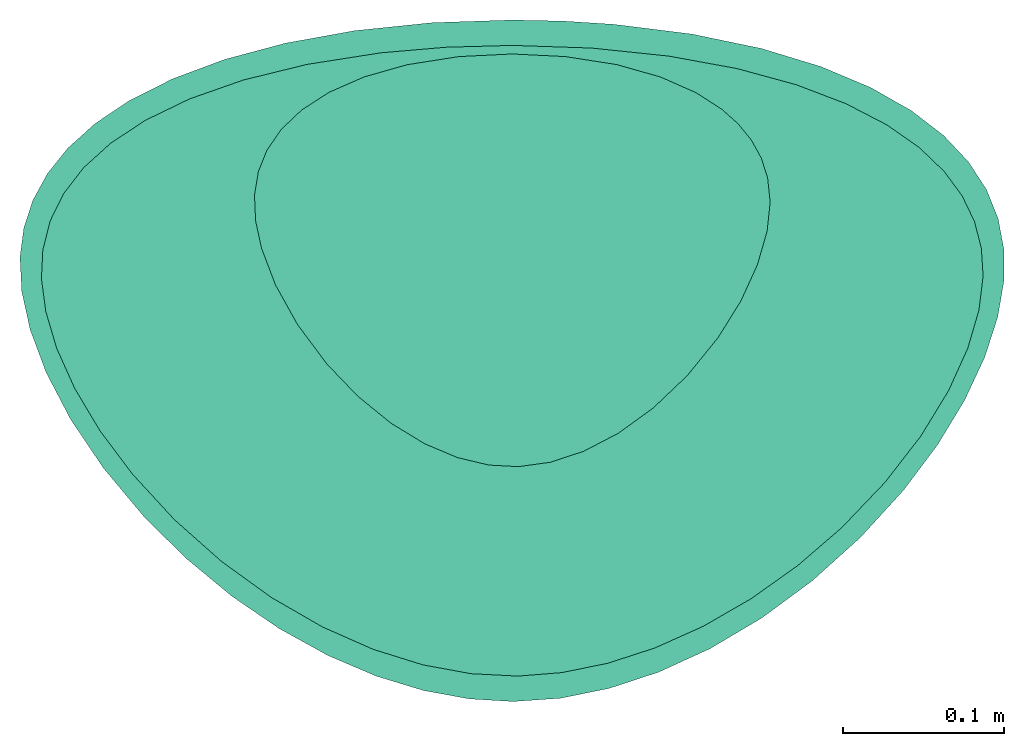
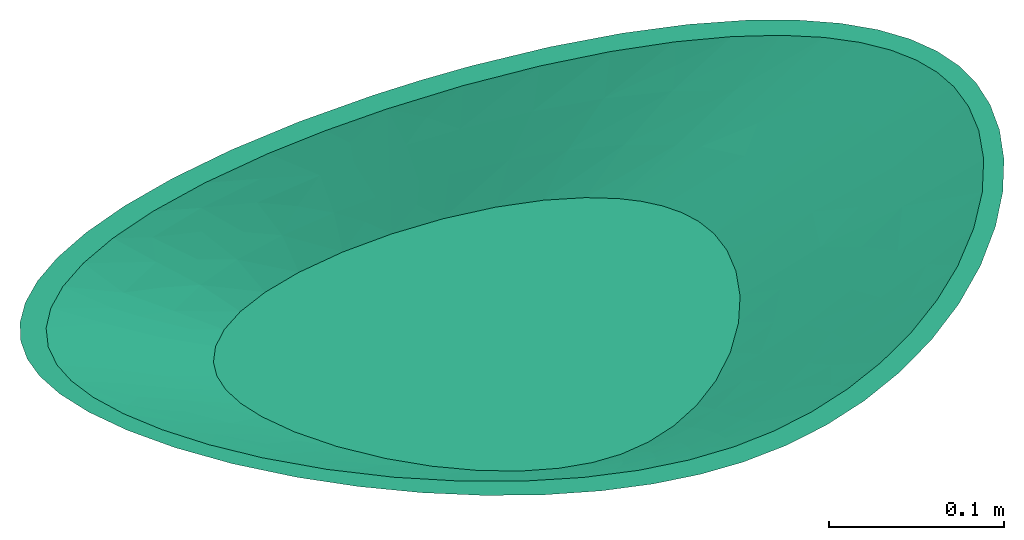
# Not in any storey: 1 sanitary terminal.
"""IFC4 building model written with IfcOpenShell, lengths in millimetres."""

from ifc_helpers import new_model, entity, si_unit, direction, origin, place, context, subcontext, project, spatial, source, transform, mapped, material, type_object, type_shapes, element, save


model = new_model("IFC4")

# Units and contexts
model_context_1 = context("Model", 3, precision=0.0001, world=origin(), true_north=direction((0.0, 1.0)))
model_context_2 = context("Model", 3, precision=0.0001, world=origin(), true_north=direction((0.0, 1.0)))
body_context = subcontext(model_context_1, "Body", "Model", "MODEL_VIEW")
ifc_project = project(units=[si_unit("LENGTHUNIT", "METRE", prefix="MILLI"), si_unit("PLANEANGLEUNIT", "RADIAN"), si_unit("TIMEUNIT", "SECOND")], contexts=[model_context_2])

# Building
building_placement = place(None, origin())
building = spatial("IfcBuilding", under=ifc_project, at=building_placement, Name="IfcBuilding", CompositionType="ELEMENT")

# Sanitary terminal
ifc_material = material(Name="Ceramic")
sanitary_terminal_type = type_object("IfcSanitaryTerminalType", PredefinedType="WASHHANDBASIN", material=ifc_material)
cartesian_point_1 = entity("IfcCartesianPoint", [0.0, 253.099263998677, 0.0])
vertex_point_1 = entity("IfcVertexPoint", cartesian_point_1)
cartesian_point_2 = entity("IfcCartesianPoint", [0.0, 247.792422124388, -83.9999999999991])
vertex_point_2 = entity("IfcVertexPoint", cartesian_point_2)
edge_curve_1 = entity("IfcEdgeCurve", vertex_point_1, vertex_point_2, entity("IfcPolyline", [cartesian_point_1, cartesian_point_2]), True)
cartesian_point_3 = entity("IfcCartesianPoint", [239.758213537139, 192.193559404919, -83.9999999999991])
cartesian_point_4 = entity("IfcCartesianPoint", [0.0, 275.591853484122, -83.9999999999991])
cartesian_point_5 = entity("IfcCartesianPoint", [-239.75821353295, 192.193559404918, -83.9999999999991])
edge_curve_2 = entity("IfcEdgeCurve", vertex_point_2, vertex_point_2, entity("IfcBSplineCurveWithKnots", 3, [cartesian_point_3, cartesian_point_4, cartesian_point_5, entity("IfcCartesianPoint", [0.0, -108.13323051355, -83.9999999999991]), cartesian_point_3, cartesian_point_4, cartesian_point_5], "UNSPECIFIED", True, True, [1, 1, 1, 1, 1, 1, 1, 1, 1, 1, 1], [-7.0, -6.0, -5.0, -4.0, -3.0, -2.0, -1.0, 0.0, 1.0, 2.0, 3.0], "UNSPECIFIED"), True)
edge_curve_3 = entity("IfcEdgeCurve", vertex_point_1, vertex_point_1, entity("IfcBSplineCurveWithKnots", 3, [entity("IfcCartesianPoint", [-437.751000004175, 168.150654933496]), entity("IfcCartesianPoint", [0.0, 295.573568531267]), entity("IfcCartesianPoint", [437.751000006541, 168.150654933498]), entity("IfcCartesianPoint", [0.0, -290.713822148428]), entity("IfcCartesianPoint", [-437.751000004175, 168.150654933496]), entity("IfcCartesianPoint", [0.0, 295.573568531267]), entity("IfcCartesianPoint", [437.751000006541, 168.150654933498])], "UNSPECIFIED", True, True, [1, 1, 1, 1, 1, 1, 1, 1, 1, 1, 1], [-7.0, -6.0, -5.0, -4.0, -3.0, -2.0, -1.0, 0.0, 1.0, 2.0, 3.0], "UNSPECIFIED"), True)
cartesian_point_6 = entity("IfcCartesianPoint", [437.751000006541, 168.150654933498, 0.0])
cartesian_point_7 = entity("IfcCartesianPoint", [0.0, 295.573568531267, 0.0])
cartesian_point_8 = entity("IfcCartesianPoint", [-437.751000004175, 168.150654933496, 0.0])
cartesian_point_9 = entity("IfcCartesianPoint", [371.75340451674, 176.164956423972, -27.9999999999997])
cartesian_point_10 = entity("IfcCartesianPoint", [0.0, 288.912996848885, -27.9999999999997])
cartesian_point_11 = entity("IfcCartesianPoint", [-371.753404513767, 176.16495642397, -27.9999999999997])
cartesian_point_12 = entity("IfcCartesianPoint", [305.75580902694, 184.179257914445, -55.9999999999994])
cartesian_point_13 = entity("IfcCartesianPoint", [0.0, 282.252425166504, -55.9999999999994])
cartesian_point_14 = entity("IfcCartesianPoint", [-305.755809023358, 184.179257914444, -55.9999999999994])
cartesian_point_15 = entity("IfcCartesianPoint", [239.758213537139, 192.193559404919, -83.9999999999991])
cartesian_point_16 = entity("IfcCartesianPoint", [0.0, 275.591853484122, -83.9999999999991])
cartesian_point_17 = entity("IfcCartesianPoint", [-239.75821353295, 192.193559404918, -83.9999999999991])
cartesian_point_18 = entity("IfcCartesianPoint", [0.0, 268.843232748677, 0.0])
vertex_point_3 = entity("IfcVertexPoint", cartesian_point_18)
cartesian_point_19 = entity("IfcCartesianPoint", [0.0, 247.792422124388, -93.9999999999991])
vertex_point_4 = entity("IfcVertexPoint", cartesian_point_19)
edge_curve_4 = entity("IfcEdgeCurve", vertex_point_3, vertex_point_4, entity("IfcPolyline", [cartesian_point_18, cartesian_point_19]), True)
cartesian_point_20 = entity("IfcCartesianPoint", [-239.758213535044, 192.193559378247, -93.9999999999991])
cartesian_point_21 = entity("IfcCartesianPoint", [0.0, 275.591853497458, -93.9999999999991])
cartesian_point_22 = entity("IfcCartesianPoint", [239.758213535045, 192.193559378248, -93.9999999999991])
edge_curve_5 = entity("IfcEdgeCurve", vertex_point_4, vertex_point_4, entity("IfcBSplineCurveWithKnots", 3, [cartesian_point_20, cartesian_point_21, cartesian_point_22, entity("IfcCartesianPoint", [0.0, -108.133230500215, -93.9999999999991]), cartesian_point_20, cartesian_point_21, cartesian_point_22], "UNSPECIFIED", True, True, [1, 1, 1, 1, 1, 1, 1, 1, 1, 1, 1], [-7.0, -6.0, -5.0, -4.0, -3.0, -2.0, -1.0, 0.0, 1.0, 2.0, 3.0], "UNSPECIFIED"), True)
edge_curve_6 = entity("IfcEdgeCurve", vertex_point_3, vertex_point_3, entity("IfcBSplineCurveWithKnots", 3, [entity("IfcCartesianPoint", [457.685108750143, 177.051077752302]), entity("IfcCartesianPoint", [0.0, 314.739310246865]), entity("IfcCartesianPoint", [-457.685108750141, 177.051077752299]), entity("IfcCartesianPoint", [0.0, -318.77998625438]), entity("IfcCartesianPoint", [457.685108750143, 177.051077752302]), entity("IfcCartesianPoint", [0.0, 314.739310246865]), entity("IfcCartesianPoint", [-457.685108750141, 177.051077752299])], "UNSPECIFIED", True, True, [1, 1, 1, 1, 1, 1, 1, 1, 1, 1, 1], [-7.0, -6.0, -5.0, -4.0, -3.0, -2.0, -1.0, 0.0, 1.0, 2.0, 3.0], "UNSPECIFIED"), True)
cartesian_point_23 = entity("IfcCartesianPoint", [-457.685108750141, 177.051077752299, 0.0])
cartesian_point_24 = entity("IfcCartesianPoint", [0.0, 314.739310246865, 0.0])
cartesian_point_25 = entity("IfcCartesianPoint", [457.685108750143, 177.051077752302, 0.0])
cartesian_point_26 = entity("IfcCartesianPoint", [-385.042810345109, 182.098571627615, -31.333333333333])
cartesian_point_27 = entity("IfcCartesianPoint", [0.0, 301.690157997063, -31.333333333333])
cartesian_point_28 = entity("IfcCartesianPoint", [385.04281034511, 182.098571627617, -31.333333333333])
cartesian_point_29 = entity("IfcCartesianPoint", [-312.400511940076, 187.146065502931, -62.666666666666])
cartesian_point_30 = entity("IfcCartesianPoint", [0.0, 288.64100574726, -62.666666666666])
cartesian_point_31 = entity("IfcCartesianPoint", [312.400511940078, 187.146065502933, -62.666666666666])
cartesian_point_32 = entity("IfcCartesianPoint", [-239.758213535044, 192.193559378247, -93.9999999999991])
cartesian_point_33 = entity("IfcCartesianPoint", [0.0, 275.591853497458, -93.9999999999991])
cartesian_point_34 = entity("IfcCartesianPoint", [239.758213535045, 192.193559378248, -93.9999999999991])
shared_shape = source(origin(), body_context, "Body", "AdvancedBrep", [
    entity("IfcAdvancedBrep", entity("IfcClosedShell", [entity("IfcAdvancedFace", [entity("IfcFaceOuterBound", entity("IfcEdgeLoop", [entity("IfcOrientedEdge", None, None, edge_curve_1, True), entity("IfcOrientedEdge", None, None, edge_curve_2, True), entity("IfcOrientedEdge", None, None, edge_curve_1, False), entity("IfcOrientedEdge", None, None, edge_curve_3, True)]), True)], entity("IfcBSplineSurfaceWithKnots", 3, 3, [[cartesian_point_6, cartesian_point_7, cartesian_point_8, entity("IfcCartesianPoint", [0.0, -290.713822148428, 0.0]), cartesian_point_6, cartesian_point_7, cartesian_point_8], [cartesian_point_9, cartesian_point_10, cartesian_point_11, entity("IfcCartesianPoint", [0.0, -229.853624936802, -27.9999999999997]), cartesian_point_9, cartesian_point_10, cartesian_point_11], [cartesian_point_12, cartesian_point_13, cartesian_point_14, entity("IfcCartesianPoint", [0.0, -168.993427725176, -55.9999999999994]), cartesian_point_12, cartesian_point_13, cartesian_point_14], [cartesian_point_15, cartesian_point_16, cartesian_point_17, entity("IfcCartesianPoint", [0.0, -108.13323051355, -83.9999999999991]), cartesian_point_15, cartesian_point_16, cartesian_point_17]], "UNSPECIFIED", False, True, False, [4, 4], [1, 1, 1, 1, 1, 1, 1, 1, 1, 1, 1], [0.0, 14.7110308353668], [-7.0, -6.0, -5.0, -4.0, -3.0, -2.0, -1.0, 0.0, 1.0, 2.0, 3.0], "UNSPECIFIED"), False), entity("IfcAdvancedFace", [entity("IfcFaceOuterBound", entity("IfcEdgeLoop", [entity("IfcOrientedEdge", None, None, edge_curve_4, True), entity("IfcOrientedEdge", None, None, edge_curve_5, True), entity("IfcOrientedEdge", None, None, edge_curve_4, False), entity("IfcOrientedEdge", None, None, edge_curve_6, True)]), True)], entity("IfcBSplineSurfaceWithKnots", 3, 3, [[cartesian_point_23, cartesian_point_24, cartesian_point_25, entity("IfcCartesianPoint", [0.0, -318.77998625438, 0.0]), cartesian_point_23, cartesian_point_24, cartesian_point_25], [cartesian_point_26, cartesian_point_27, cartesian_point_28, entity("IfcCartesianPoint", [0.0, -248.564401002992, -31.333333333333]), cartesian_point_26, cartesian_point_27, cartesian_point_28], [cartesian_point_29, cartesian_point_30, cartesian_point_31, entity("IfcCartesianPoint", [0.0, -178.348815751603, -62.6666666666661]), cartesian_point_29, cartesian_point_30, cartesian_point_31], [cartesian_point_32, cartesian_point_33, cartesian_point_34, entity("IfcCartesianPoint", [0.0, -108.133230500215, -93.9999999999991]), cartesian_point_32, cartesian_point_33, cartesian_point_34]], "UNSPECIFIED", False, True, False, [4, 4], [1, 1, 1, 1, 1, 1, 1, 1, 1, 1, 1], [0.0, 15.4213505620632], [-3.0, -2.0, -1.0, 0.0, 1.0, 2.0, 3.0, 4.0, 5.0, 6.0, 7.0], "UNSPECIFIED"), False), entity("IfcAdvancedFace", [entity("IfcFaceOuterBound", entity("IfcEdgeLoop", [entity("IfcOrientedEdge", None, None, edge_curve_2, False)]), True)], entity("IfcPlane", entity("IfcAxis2Placement3D", cartesian_point_2)), True), entity("IfcAdvancedFace", [entity("IfcFaceOuterBound", entity("IfcEdgeLoop", [entity("IfcOrientedEdge", None, None, edge_curve_5, True)]), True)], entity("IfcPlane", entity("IfcAxis2Placement3D", cartesian_point_19)), False), entity("IfcAdvancedFace", [entity("IfcFaceOuterBound", entity("IfcEdgeLoop", [entity("IfcOrientedEdge", None, None, edge_curve_6, False)]), True), entity("IfcFaceBound", entity("IfcEdgeLoop", [entity("IfcOrientedEdge", None, None, edge_curve_3, False)]), True)], entity("IfcPlane", entity("IfcAxis2Placement3D", cartesian_point_1)), True)])),
])
type_shapes(sanitary_terminal_type, [shared_shape])
sanitary_terminal_placement = place(building_placement, origin())
element("IfcSanitaryTerminal", 1, at=sanitary_terminal_placement, inside=building, type_object=sanitary_terminal_type, PredefinedType="NOTDEFINED", context=body_context, shape_type="MappedRepresentation", body=[
    mapped(shared_shape, transform((0.0, 0.0, 0.0), x_axis=(1.0, 0.0, 0.0), y_axis=(0.0, 1.0, 0.0), z_axis=(0.0, 0.0, 1.0), scale=1.0)),
])

save(model, "model.ifc")
